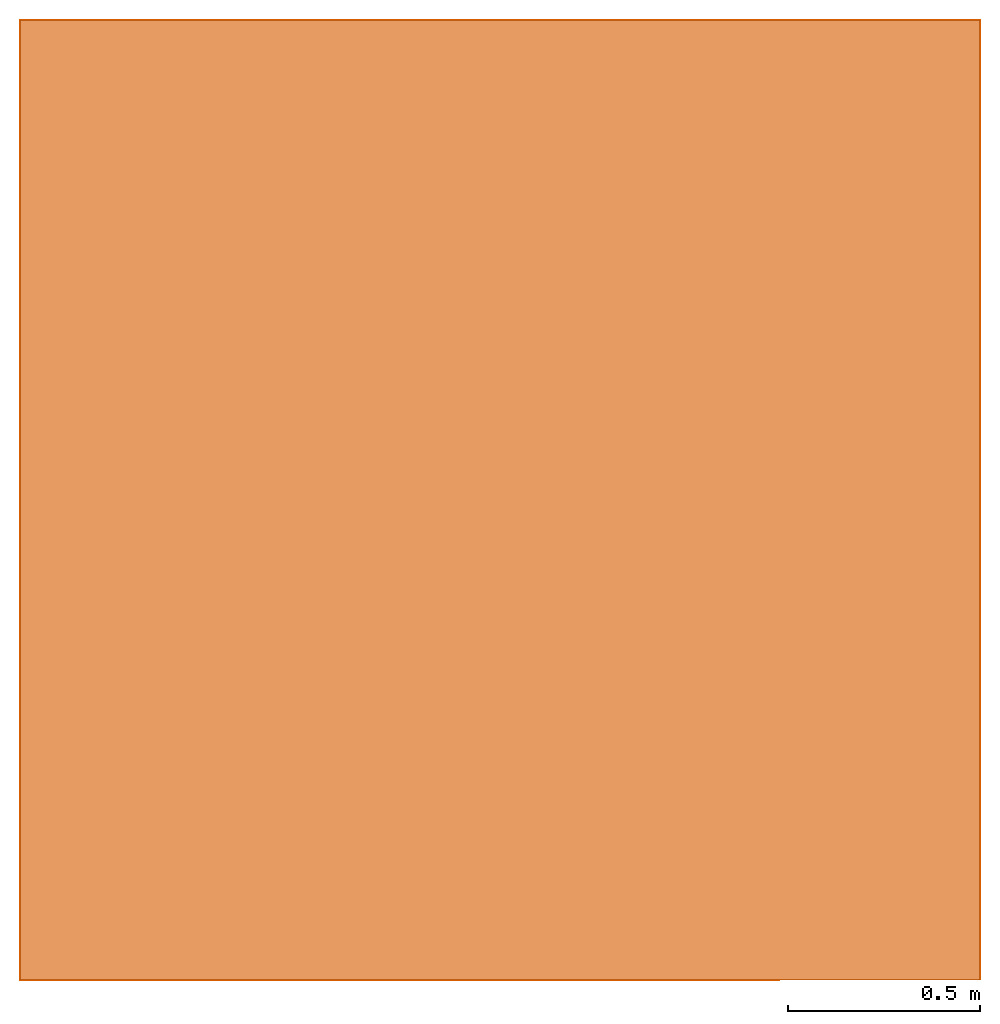
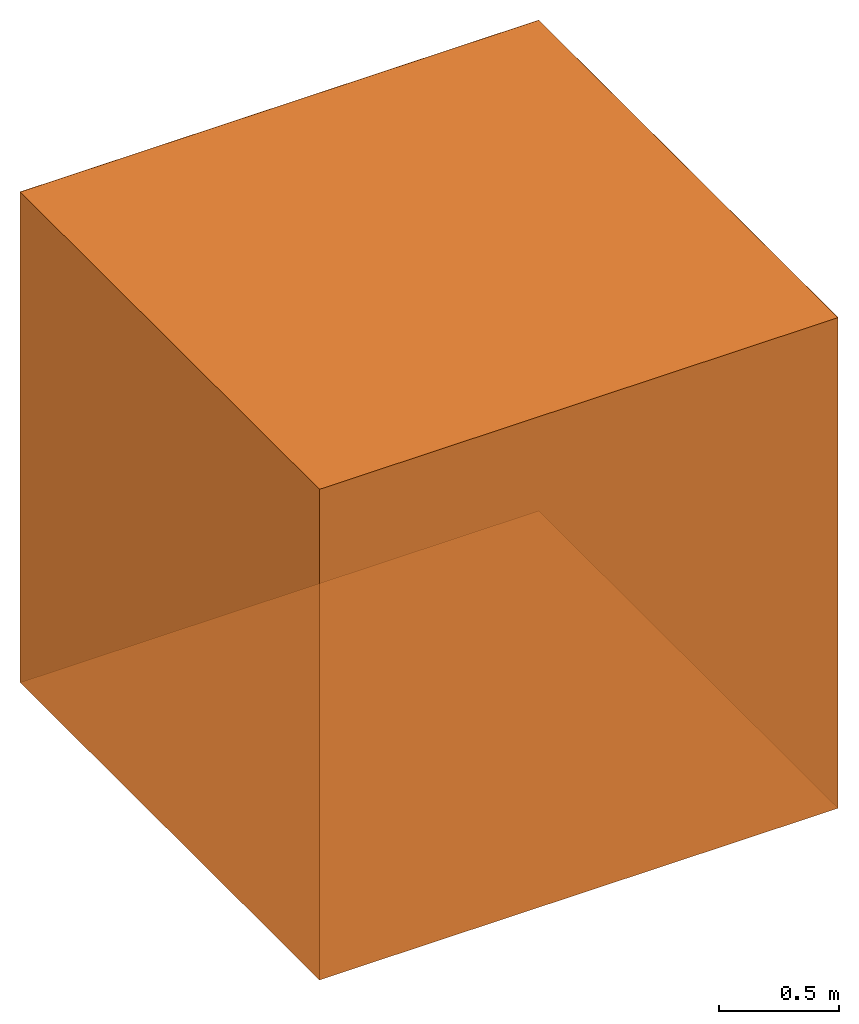
# Not in any storey: 6 virtual elements, 1 element without a shape of its own.
"""IFC4 building model written with IfcOpenShell, lengths in metres."""

from ifc_helpers import new_model, si_unit, origin_with_axes, origin_2d_with_axis, place, context, subcontext, project, library, spatial, polygons, element, aggregate, save


model = new_model("IFC4")

# Units and contexts
model_context = context("Model", 3, precision=1e-05, world=origin_with_axes())
plan_context = context("Plan", 2, precision=1e-05, world=origin_2d_with_axis())
surface_context = subcontext(model_context, "Surface", "Model", "SKETCH_VIEW")
ifc_project = project(units=[si_unit("LENGTHUNIT", "METRE"), si_unit("AREAUNIT", "SQUARE_METRE"), si_unit("VOLUMEUNIT", "CUBIC_METRE"), si_unit("PLANEANGLEUNIT", "RADIAN")], contexts=[model_context, plan_context])
project_library = library(declared=ifc_project)

# Site, building
site = spatial("IfcSite", under=ifc_project)
building = spatial("IfcBuilding", under=site, Name="Cube")

# Virtual elements
virtual_element_1_placement = place(None, origin_with_axes())
virtual_element_1 = element("IfcVirtualElement", 1, at=virtual_element_1_placement, inside=building, Name="CellComplex")
virtual_element_2 = element("IfcVirtualElement", 2, Name="face/0", context=surface_context, identifier="Surface", shape_type="Tessellation", body=[
    polygons([(2.5, 2.5, 2.5), (0.0, 2.5, 2.5), (0.0, 0.0, 2.5), (2.5, 0.0, 2.5)], [[[1, 2, 3, 4]]]),
])
virtual_element_3 = element("IfcVirtualElement", 3, Name="face/1", context=surface_context, identifier="Surface", shape_type="Tessellation", body=[
    polygons([(0.0, 2.5, 2.5), (0.0, 2.5, 0.0), (2.5, 2.5, 2.5), (2.5, 2.5, 0.0)], [[[1, 3, 4, 2]]]),
])
virtual_element_4 = element("IfcVirtualElement", 4, Name="face/2", context=surface_context, identifier="Surface", shape_type="Tessellation", body=[
    polygons([(2.5, 2.5, 0.0), (2.5, 2.5, 2.5), (2.5, 0.0, 2.5), (2.5, 0.0, 0.0)], [[[1, 2, 3, 4]]]),
])
virtual_element_5 = element("IfcVirtualElement", 5, Name="face/3", context=surface_context, identifier="Surface", shape_type="Tessellation", body=[
    polygons([(0.0, 0.0, 2.5), (0.0, 0.0, 0.0), (0.0, 2.5, 2.5), (0.0, 2.5, 0.0)], [[[1, 3, 4, 2]]]),
])
virtual_element_6 = element("IfcVirtualElement", 6, Name="face/4", context=surface_context, identifier="Surface", shape_type="Tessellation", body=[
    polygons([(2.5, 0.0, 0.0), (2.5, 0.0, 2.5), (0.0, 0.0, 2.5), (0.0, 0.0, 0.0)], [[[1, 2, 3, 4]]]),
])
virtual_element_7 = element("IfcVirtualElement", 7, Name="face/5", context=surface_context, identifier="Surface", shape_type="Tessellation", body=[
    polygons([(0.0, 2.5, 0.0), (2.5, 2.5, 0.0), (2.5, 0.0, 0.0), (0.0, 0.0, 0.0)], [[[1, 2, 3, 4]]]),
])
aggregate(virtual_element_1, [virtual_element_2, virtual_element_3, virtual_element_4, virtual_element_5, virtual_element_6, virtual_element_7])

save(model, "model.ifc")
